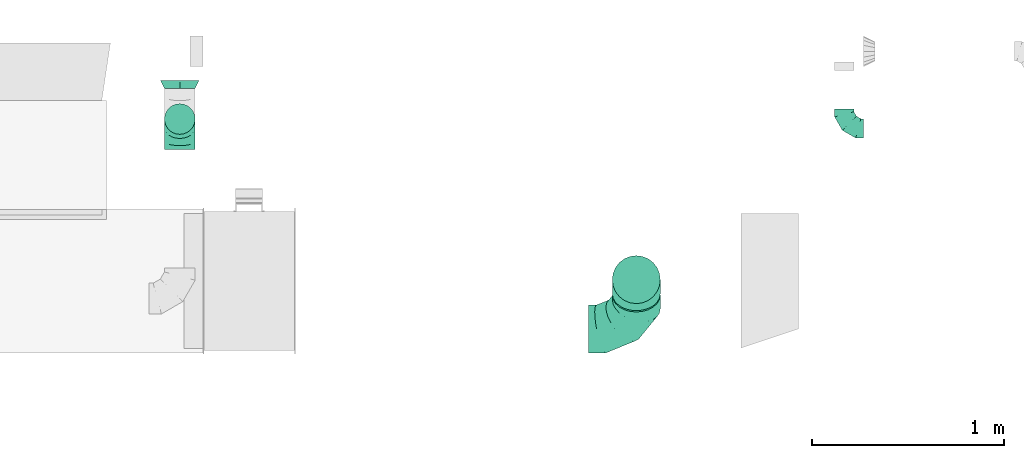
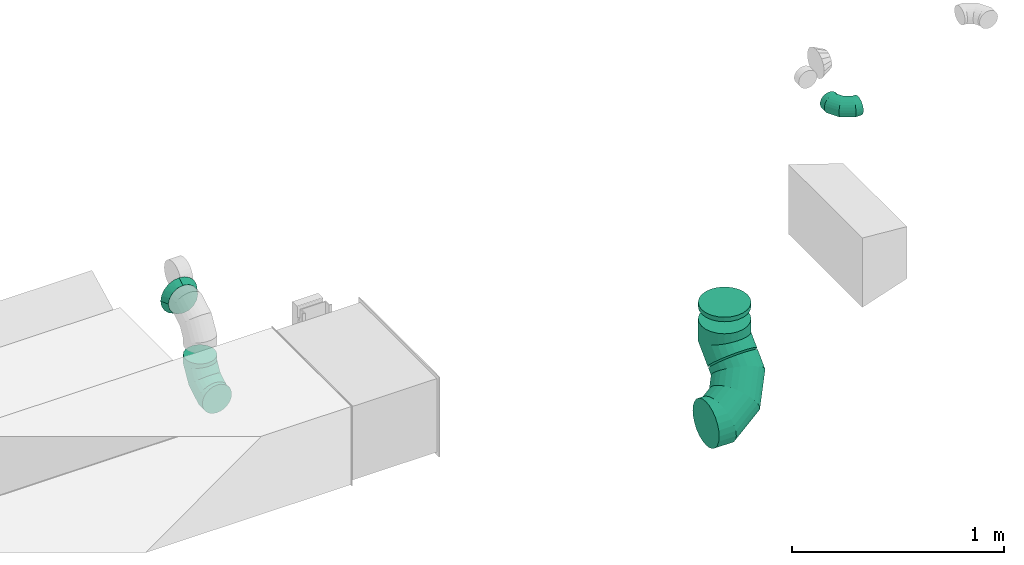
# One storey, part 17 of 62: 6 flow fittings.
"""IFC2X3 building model written with IfcOpenShell, lengths in millimetres."""

from ifc_helpers import new_model, entity, si_unit, converted_unit, derived_unit, direction, frame, origin, place, context, subcontext, project, spatial, faceted_brep, source, transform, mapped, material, type_object, type_shapes, element, save


model = new_model("IFC2X3")

# Units and contexts
model_context = context("Model", 3, precision=0.01, world=origin(), true_north=direction((6.12303176911189e-17, 1.0)))
body_context = subcontext(model_context, "Body", "Model", "MODEL_VIEW")
ifc_project = project(units=[si_unit("LENGTHUNIT", "METRE", prefix="MILLI"), si_unit("AREAUNIT", "SQUARE_METRE"), si_unit("VOLUMEUNIT", "CUBIC_METRE"), converted_unit("PLANEANGLEUNIT", "DEGREE", entity("IfcRatioMeasure", 0.0174532925199433), si_unit("PLANEANGLEUNIT", "RADIAN"), dimensions=[0, 0, 0, 0, 0, 0, 0]), si_unit("MASSUNIT", "GRAM", prefix="KILO"), derived_unit("MASSDENSITYUNIT", [(si_unit("MASSUNIT", "GRAM", prefix="KILO"), 1), (si_unit("LENGTHUNIT", "METRE"), -3)]), derived_unit("MOMENTOFINERTIAUNIT", [(si_unit("LENGTHUNIT", "METRE"), 4)]), si_unit("TIMEUNIT", "SECOND"), si_unit("FREQUENCYUNIT", "HERTZ"), si_unit("THERMODYNAMICTEMPERATUREUNIT", "DEGREE_CELSIUS"), derived_unit("THERMALTRANSMITTANCEUNIT", [(si_unit("MASSUNIT", "GRAM", prefix="KILO"), 1), (si_unit("THERMODYNAMICTEMPERATUREUNIT", "KELVIN"), -1), (si_unit("TIMEUNIT", "SECOND"), -3)]), derived_unit("VOLUMETRICFLOWRATEUNIT", [(si_unit("LENGTHUNIT", "METRE"), 3), (si_unit("TIMEUNIT", "SECOND"), -1)]), derived_unit("MASSFLOWRATEUNIT", [(si_unit("MASSUNIT", "GRAM", prefix="KILO"), 1), (si_unit("TIMEUNIT", "SECOND"), -1)]), derived_unit("ROTATIONALFREQUENCYUNIT", [(si_unit("TIMEUNIT", "SECOND"), -1)]), si_unit("ELECTRICCURRENTUNIT", "AMPERE"), si_unit("ELECTRICVOLTAGEUNIT", "VOLT"), si_unit("POWERUNIT", "WATT"), si_unit("FORCEUNIT", "NEWTON", prefix="KILO"), si_unit("ILLUMINANCEUNIT", "LUX"), si_unit("LUMINOUSFLUXUNIT", "LUMEN"), si_unit("LUMINOUSINTENSITYUNIT", "CANDELA"), derived_unit("USERDEFINED", [(si_unit("MASSUNIT", "GRAM", prefix="KILO"), -1), (si_unit("LENGTHUNIT", "METRE"), -2), (si_unit("TIMEUNIT", "SECOND"), 3), (si_unit("LUMINOUSFLUXUNIT", "LUMEN"), 1)]), derived_unit("LINEARVELOCITYUNIT", [(si_unit("LENGTHUNIT", "METRE"), 1), (si_unit("TIMEUNIT", "SECOND"), -1)]), si_unit("PRESSUREUNIT", "PASCAL"), derived_unit("USERDEFINED", [(si_unit("LENGTHUNIT", "METRE"), -2), (si_unit("MASSUNIT", "GRAM", prefix="KILO"), 1), (si_unit("TIMEUNIT", "SECOND"), -2)]), derived_unit("LINEARFORCEUNIT", [(si_unit("MASSUNIT", "GRAM", prefix="KILO"), 1), (si_unit("LENGTHUNIT", "METRE"), 1), (si_unit("TIMEUNIT", "SECOND"), -2), (si_unit("LENGTHUNIT", "METRE"), -1)]), derived_unit("PLANARFORCEUNIT", [(si_unit("MASSUNIT", "GRAM", prefix="KILO"), 1), (si_unit("LENGTHUNIT", "METRE"), 1), (si_unit("TIMEUNIT", "SECOND"), -2), (si_unit("LENGTHUNIT", "METRE"), -2)])], contexts=[model_context])

# Site, building, storey
site_placement = place(None, origin())
site = spatial("IfcSite", under=ifc_project, at=site_placement, CompositionType="ELEMENT")
building_placement = place(site_placement, origin())
building = spatial("IfcBuilding", under=site, at=building_placement, CompositionType="ELEMENT")
storey_placement = place(building_placement, frame((0.0, 0.0, 24000.0)))
storey = spatial("IfcBuildingStorey", under=building, at=storey_placement, CompositionType="ELEMENT", Elevation=24000.0)

# Flow fittings
ifc_material = material()
duct_fitting_type_1 = type_object("IfcDuctFittingType", PredefinedType="NOTDEFINED", material=ifc_material)
shared_shape_1 = source(origin(), body_context, "Body", "Brep", [
    faceted_brep([(-160.0, 0.0, -80.0), (-160.0, -20.71, -77.27), (-160.0, -40.0, -69.28), (-160.0, -56.57, -56.57), (-160.0, -69.28, -40.0), (-160.0, -77.27, -20.71), (-160.0, -80.0, 0.0), (-160.0, -77.27, 20.71), (-160.0, -69.28, 40.0), (-160.0, -56.57, 56.57), (-160.0, -40.0, 69.28), (-160.0, -20.71, 77.27), (-160.0, 0.0, 80.0), (-160.0, 20.71, 77.27), (-160.0, 40.0, 69.28), (-160.0, 56.57, 56.57), (-160.0, 69.28, 40.0), (-160.0, 77.27, 20.71), (-160.0, 80.0, 0.0), (-160.0, 77.27, -20.71), (-160.0, 69.28, -40.0), (-160.0, 56.57, -56.57), (-160.0, 40.0, -69.28), (-160.0, 20.71, -77.27), (-122.68, 20.71, 77.27), (-127.85, 40.0, 69.28), (-117.13, 0.0, 80.0), (-132.29, 56.57, 56.57), (-137.83, 77.27, 20.71), (-138.56, 80.0, 0.0), (-135.69, 69.28, 40.0), (-135.69, 69.28, -40.0), (-132.29, 56.57, -56.57), (-137.83, 77.27, -20.71), (-122.68, 20.71, -77.27), (-117.13, 0.0, -80.0), (-127.85, 40.0, -69.28), (-111.58, -20.71, -77.27), (-106.41, -40.0, -69.28), (-101.97, -56.57, -56.57), (-98.56, -69.28, -40.0), (-96.42, -77.27, -20.71), (-95.69, -80.0, 0.0), (-96.42, -77.27, 20.71), (-98.56, -69.28, 40.0), (-101.97, -56.57, 56.57), (-106.41, -40.0, 69.28), (-111.58, -20.71, 77.27), (-58.03, 58.03, 77.27), (-72.15, 72.15, 69.28), (-42.87, 42.87, 80.0), (-84.28, 84.28, 56.57), (-93.59, 93.59, 40.0), (-99.44, 99.44, 20.71), (-101.44, 101.44, 0.0), (-99.44, 99.44, -20.71), (-93.59, 93.59, -40.0), (-84.28, 84.28, -56.57), (-58.03, 58.03, -77.27), (-42.87, 42.87, -80.0), (-72.15, 72.15, -69.28), (-27.71, 27.71, -77.27), (-13.59, 13.59, -69.28), (-1.46, 1.46, -56.57), (7.85, -7.85, -40.0), (13.7, -13.7, -20.71), (15.69, -15.69, 0.0), (13.7, -13.7, 20.71), (7.85, -7.85, 40.0), (-1.46, 1.46, 56.57), (-13.59, 13.59, 69.28), (-27.71, 27.71, 77.27), (-20.71, 122.68, 77.27), (-40.0, 127.85, 69.28), (0.0, 117.13, 80.0), (-56.57, 132.29, 56.57), (-69.28, 135.69, 40.0), (-77.27, 137.83, 20.71), (-80.0, 138.56, 0.0), (-77.27, 137.83, -20.71), (-69.28, 135.69, -40.0), (-56.57, 132.29, -56.57), (-20.71, 122.68, -77.27), (0.0, 117.13, -80.0), (-40.0, 127.85, -69.28), (20.71, 111.58, -77.27), (40.0, 106.41, -69.28), (56.57, 101.97, -56.57), (69.28, 98.56, -40.0), (77.27, 96.42, -20.71), (80.0, 95.69, 0.0), (77.27, 96.42, 20.71), (69.28, 98.56, 40.0), (56.57, 101.97, 56.57), (40.0, 106.41, 69.28), (20.71, 111.58, 77.27), (-20.71, 160.0, -77.27), (-40.0, 160.0, -69.28), (-56.57, 160.0, -56.57), (-69.28, 160.0, -40.0), (-77.27, 160.0, -20.71), (-80.0, 160.0, 0.0), (-77.27, 160.0, 20.71), (-69.28, 160.0, 40.0), (-56.57, 160.0, 56.57), (-40.0, 160.0, 69.28), (-20.71, 160.0, 77.27), (0.0, 160.0, 80.0), (20.71, 160.0, 77.27), (40.0, 160.0, 69.28), (56.57, 160.0, 56.57), (69.28, 160.0, 40.0), (77.27, 160.0, 20.71), (80.0, 160.0, 0.0), (77.27, 160.0, -20.71), (69.28, 160.0, -40.0), (56.57, 160.0, -56.57), (40.0, 160.0, -69.28), (20.71, 160.0, -77.27), (0.0, 160.0, -80.0)], [[[0, 1, 2, 3, 4, 5, 6, 7, 8, 9, 10, 11, 12, 13, 14, 15, 16, 17, 18, 19, 20, 21, 22, 23]], [[24, 25, 14, 13]], [[26, 24, 13, 12]], [[14, 25, 27, 15]], [[28, 29, 18, 17]], [[30, 28, 17, 16]], [[15, 27, 30, 16]], [[20, 31, 32, 21]], [[33, 31, 20, 19]], [[18, 29, 33, 19]], [[34, 35, 0, 23]], [[36, 34, 23, 22]], [[32, 36, 22, 21]], [[1, 0, 35, 37]], [[2, 1, 37, 38]], [[3, 2, 38, 39]], [[5, 4, 40, 41]], [[6, 5, 41, 42]], [[39, 40, 4, 3]], [[6, 42, 43, 7]], [[7, 43, 44, 8]], [[8, 44, 45, 9]], [[9, 45, 46, 10]], [[10, 46, 47, 11]], [[26, 12, 11, 47]], [[48, 49, 25, 24]], [[50, 48, 24, 26]], [[27, 25, 49, 51]], [[52, 53, 28, 30]], [[51, 52, 30, 27]], [[29, 28, 53, 54]], [[55, 56, 31, 33]], [[54, 55, 33, 29]], [[32, 31, 56, 57]], [[58, 59, 35, 34]], [[60, 58, 34, 36]], [[57, 60, 36, 32]], [[37, 35, 59, 61]], [[38, 37, 61, 62]], [[39, 38, 62, 63]], [[41, 40, 64, 65]], [[42, 41, 65, 66]], [[63, 64, 40, 39]], [[43, 42, 66, 67]], [[44, 43, 67, 68]], [[68, 69, 45, 44]], [[46, 45, 69, 70]], [[47, 46, 70, 71]], [[26, 47, 71, 50]], [[72, 73, 49, 48]], [[74, 72, 48, 50]], [[51, 49, 73, 75]], [[76, 77, 53, 52]], [[75, 76, 52, 51]], [[54, 53, 77, 78]], [[79, 80, 56, 55]], [[78, 79, 55, 54]], [[57, 56, 80, 81]], [[82, 83, 59, 58]], [[84, 82, 58, 60]], [[81, 84, 60, 57]], [[61, 59, 83, 85]], [[62, 61, 85, 86]], [[63, 62, 86, 87]], [[65, 64, 88, 89]], [[66, 65, 89, 90]], [[87, 88, 64, 63]], [[67, 66, 90, 91]], [[68, 67, 91, 92]], [[92, 93, 69, 68]], [[70, 69, 93, 94]], [[71, 70, 94, 95]], [[50, 71, 95, 74]], [[96, 97, 98, 99, 100, 101, 102, 103, 104, 105, 106, 107, 108, 109, 110, 111, 112, 113, 114, 115, 116, 117, 118, 119]], [[72, 74, 107, 106]], [[73, 72, 106, 105]], [[75, 73, 105, 104]], [[77, 76, 103, 102]], [[78, 77, 102, 101]], [[75, 104, 103, 76]], [[78, 101, 100, 79]], [[79, 100, 99, 80]], [[80, 99, 98, 81]], [[84, 97, 96, 82]], [[82, 96, 119, 83]], [[84, 81, 98, 97]], [[118, 117, 86, 85]], [[119, 118, 85, 83]], [[116, 87, 86, 117]], [[88, 115, 114, 89]], [[89, 114, 113, 90]], [[115, 88, 87, 116]], [[112, 111, 92, 91]], [[113, 112, 91, 90]], [[111, 110, 93, 92]], [[95, 94, 109, 108]], [[74, 95, 108, 107]], [[110, 109, 94, 93]]]),
])
type_shapes(duct_fitting_type_1, [shared_shape_1])
flow_fitting_1_placement = place(storey_placement, frame((31130.5, 2136.51, 3220.0), z_axis=(-1.0, 0.0, 0.0), x_axis=(0.0, 0.0, -1.0)))
element("IfcFlowFitting", 1, at=flow_fitting_1_placement, inside=storey, type_object=duct_fitting_type_1, material=ifc_material, context=body_context, shape_type="MappedRepresentation", body=[
    mapped(shared_shape_1, transform((0.0, 0.0, 0.0), scale=1.0)),
])
duct_fitting_type_2 = type_object("IfcDuctFittingType", PredefinedType="NOTDEFINED", material=ifc_material)
shared_shape_2 = source(origin(), body_context, "Body", "Brep", [
    faceted_brep([(-100.0, 0.0, -50.0), (-100.0, -12.94, -48.3), (-100.0, -25.0, -43.3), (-100.0, -35.36, -35.36), (-100.0, -43.3, -25.0), (-100.0, -48.3, -12.94), (-100.0, -50.0, 0.0), (-100.0, -48.3, 12.94), (-100.0, -43.3, 25.0), (-100.0, -35.36, 35.36), (-100.0, -25.0, 43.3), (-100.0, -12.94, 48.3), (-100.0, 0.0, 50.0), (-100.0, 12.94, 48.3), (-100.0, 25.0, 43.3), (-100.0, 35.36, 35.36), (-100.0, 43.3, 25.0), (-100.0, 48.3, 12.94), (-100.0, 50.0, 0.0), (-100.0, 48.3, -12.94), (-100.0, 43.3, -25.0), (-100.0, 35.36, -35.36), (-100.0, 25.0, -43.3), (-100.0, 12.94, -48.3), (-76.67, 12.94, 48.3), (-79.9, 25.0, 43.3), (-73.21, 0.0, 50.0), (-82.68, 35.36, 35.36), (-86.15, 48.3, 12.94), (-86.6, 50.0, 0.0), (-84.81, 43.3, 25.0), (-84.81, 43.3, -25.0), (-82.68, 35.36, -35.36), (-86.15, 48.3, -12.94), (-76.67, 12.94, -48.3), (-73.21, 0.0, -50.0), (-79.9, 25.0, -43.3), (-69.74, -12.94, -48.3), (-66.51, -25.0, -43.3), (-63.73, -35.36, -35.36), (-61.6, -43.3, -25.0), (-60.26, -48.3, -12.94), (-59.81, -50.0, 0.0), (-60.26, -48.3, 12.94), (-61.6, -43.3, 25.0), (-63.73, -35.36, 35.36), (-66.51, -25.0, 43.3), (-69.74, -12.94, 48.3), (-36.27, 36.27, 48.3), (-45.1, 45.1, 43.3), (-26.79, 26.79, 50.0), (-52.68, 52.68, 35.36), (-58.49, 58.49, 25.0), (-62.15, 62.15, 12.94), (-63.4, 63.4, 0.0), (-62.15, 62.15, -12.94), (-58.49, 58.49, -25.0), (-52.68, 52.68, -35.36), (-36.27, 36.27, -48.3), (-26.79, 26.79, -50.0), (-45.1, 45.1, -43.3), (-17.32, 17.32, -48.3), (-8.49, 8.49, -43.3), (-0.91, 0.91, -35.36), (4.9, -4.9, -25.0), (8.56, -8.56, -12.94), (9.81, -9.81, 0.0), (8.56, -8.56, 12.94), (4.9, -4.9, 25.0), (-0.91, 0.91, 35.36), (-8.49, 8.49, 43.3), (-17.32, 17.32, 48.3), (-12.94, 76.67, 48.3), (-25.0, 79.9, 43.3), (0.0, 73.21, 50.0), (-35.36, 82.68, 35.36), (-43.3, 84.81, 25.0), (-48.3, 86.15, 12.94), (-50.0, 86.6, 0.0), (-48.3, 86.15, -12.94), (-43.3, 84.81, -25.0), (-35.36, 82.68, -35.36), (-12.94, 76.67, -48.3), (0.0, 73.21, -50.0), (-25.0, 79.9, -43.3), (12.94, 69.74, -48.3), (25.0, 66.51, -43.3), (35.36, 63.73, -35.36), (43.3, 61.6, -25.0), (48.3, 60.26, -12.94), (50.0, 59.81, 0.0), (48.3, 60.26, 12.94), (43.3, 61.6, 25.0), (35.36, 63.73, 35.36), (25.0, 66.51, 43.3), (12.94, 69.74, 48.3), (-12.94, 100.0, -48.3), (-25.0, 100.0, -43.3), (-35.36, 100.0, -35.36), (-43.3, 100.0, -25.0), (-48.3, 100.0, -12.94), (-50.0, 100.0, 0.0), (-48.3, 100.0, 12.94), (-43.3, 100.0, 25.0), (-35.36, 100.0, 35.36), (-25.0, 100.0, 43.3), (-12.94, 100.0, 48.3), (0.0, 100.0, 50.0), (12.94, 100.0, 48.3), (25.0, 100.0, 43.3), (35.36, 100.0, 35.36), (43.3, 100.0, 25.0), (48.3, 100.0, 12.94), (50.0, 100.0, 0.0), (48.3, 100.0, -12.94), (43.3, 100.0, -25.0), (35.36, 100.0, -35.36), (25.0, 100.0, -43.3), (12.94, 100.0, -48.3), (0.0, 100.0, -50.0)], [[[0, 1, 2, 3, 4, 5, 6, 7, 8, 9, 10, 11, 12, 13, 14, 15, 16, 17, 18, 19, 20, 21, 22, 23]], [[24, 25, 14, 13]], [[26, 24, 13, 12]], [[14, 25, 27, 15]], [[28, 29, 18, 17]], [[30, 28, 17, 16]], [[15, 27, 30, 16]], [[20, 31, 32, 21]], [[33, 31, 20, 19]], [[18, 29, 33, 19]], [[34, 35, 0, 23]], [[36, 34, 23, 22]], [[32, 36, 22, 21]], [[2, 1, 37, 38]], [[3, 2, 38, 39]], [[0, 35, 37, 1]], [[5, 4, 40, 41]], [[6, 5, 41, 42]], [[3, 39, 40, 4]], [[6, 42, 43, 7]], [[7, 43, 44, 8]], [[8, 44, 45, 9]], [[10, 46, 47, 11]], [[11, 47, 26, 12]], [[10, 9, 45, 46]], [[48, 49, 25, 24]], [[50, 48, 24, 26]], [[27, 25, 49, 51]], [[52, 53, 28, 30]], [[51, 52, 30, 27]], [[29, 28, 53, 54]], [[55, 56, 31, 33]], [[54, 55, 33, 29]], [[57, 32, 31, 56]], [[58, 59, 35, 34]], [[60, 58, 34, 36]], [[57, 60, 36, 32]], [[37, 35, 59, 61]], [[38, 37, 61, 62]], [[39, 38, 62, 63]], [[41, 40, 64, 65]], [[42, 41, 65, 66]], [[63, 64, 40, 39]], [[43, 42, 66, 67]], [[44, 43, 67, 68]], [[68, 69, 45, 44]], [[46, 45, 69, 70]], [[47, 46, 70, 71]], [[26, 47, 71, 50]], [[72, 73, 49, 48]], [[74, 72, 48, 50]], [[51, 49, 73, 75]], [[76, 77, 53, 52]], [[75, 76, 52, 51]], [[54, 53, 77, 78]], [[79, 80, 56, 55]], [[78, 79, 55, 54]], [[81, 57, 56, 80]], [[82, 83, 59, 58]], [[84, 82, 58, 60]], [[81, 84, 60, 57]], [[61, 59, 83, 85]], [[62, 61, 85, 86]], [[63, 62, 86, 87]], [[65, 64, 88, 89]], [[66, 65, 89, 90]], [[87, 88, 64, 63]], [[67, 66, 90, 91]], [[68, 67, 91, 92]], [[92, 93, 69, 68]], [[70, 69, 93, 94]], [[71, 70, 94, 95]], [[50, 71, 95, 74]], [[96, 97, 98, 99, 100, 101, 102, 103, 104, 105, 106, 107, 108, 109, 110, 111, 112, 113, 114, 115, 116, 117, 118, 119]], [[72, 74, 107, 106]], [[73, 72, 106, 105]], [[75, 73, 105, 104]], [[77, 76, 103, 102]], [[78, 77, 102, 101]], [[75, 104, 103, 76]], [[78, 101, 100, 79]], [[79, 100, 99, 80]], [[80, 99, 98, 81]], [[96, 119, 83, 82]], [[97, 96, 82, 84]], [[84, 81, 98, 97]], [[83, 119, 118, 85]], [[85, 118, 117, 86]], [[86, 117, 116, 87]], [[88, 115, 114, 89]], [[89, 114, 113, 90]], [[87, 116, 115, 88]], [[91, 90, 113, 112]], [[92, 91, 112, 111]], [[93, 92, 111, 110]], [[95, 94, 109, 108]], [[74, 95, 108, 107]], [[110, 109, 94, 93]]]),
])
type_shapes(duct_fitting_type_2, [shared_shape_2])
flow_fitting_2_placement = place(storey_placement, frame((34589.9, 2087.55, 3600.0), z_axis=(0.0, 0.0, 1.0), x_axis=(0.0, -1.0, 0.0)))
element("IfcFlowFitting", 2, at=flow_fitting_2_placement, inside=storey, type_object=duct_fitting_type_2, material=ifc_material, context=body_context, shape_type="MappedRepresentation", body=[
    mapped(shared_shape_2, transform((0.0, 0.0, 0.0), scale=1.0)),
])
duct_fitting_type_3 = type_object("IfcDuctFittingType", PredefinedType="NOTDEFINED", material=ifc_material)
shared_shape_3 = source(origin(), body_context, "Body", "Brep", [
    faceted_brep([(-250.0, 0.0, -125.0), (-250.0, -32.35, -120.74), (-250.0, -62.5, -108.25), (-250.0, -88.39, -88.39), (-250.0, -108.25, -62.5), (-250.0, -120.74, -32.35), (-250.0, -125.0, 0.0), (-250.0, -120.74, 32.35), (-250.0, -108.25, 62.5), (-250.0, -88.39, 88.39), (-250.0, -62.5, 108.25), (-250.0, -32.35, 120.74), (-250.0, 0.0, 125.0), (-250.0, 32.35, 120.74), (-250.0, 62.5, 108.25), (-250.0, 88.39, 88.39), (-250.0, 108.25, 62.5), (-250.0, 120.74, 32.35), (-250.0, 125.0, 0.0), (-250.0, 120.74, -32.35), (-250.0, 108.25, -62.5), (-250.0, 88.39, -88.39), (-250.0, 62.5, -108.25), (-250.0, 32.35, -120.74), (-191.68, 32.35, 120.74), (-199.76, 62.5, 108.25), (-183.01, 0.0, 125.0), (-206.7, 88.39, 88.39), (-215.37, 120.74, 32.35), (-216.51, 125.0, 0.0), (-212.02, 108.25, 62.5), (-212.02, 108.25, -62.5), (-206.7, 88.39, -88.39), (-215.37, 120.74, -32.35), (-191.68, 32.35, -120.74), (-183.01, 0.0, -125.0), (-199.76, 62.5, -108.25), (-174.34, -32.35, -120.74), (-166.27, -62.5, -108.25), (-159.33, -88.39, -88.39), (-154.01, -108.25, -62.5), (-150.66, -120.74, -32.35), (-149.52, -125.0, 0.0), (-150.66, -120.74, 32.35), (-154.01, -108.25, 62.5), (-159.33, -88.39, 88.39), (-166.27, -62.5, 108.25), (-174.34, -32.35, 120.74), (-90.67, 90.67, 120.74), (-112.74, 112.74, 108.25), (-66.99, 66.99, 125.0), (-131.69, 131.69, 88.39), (-146.23, 146.23, 62.5), (-155.38, 155.38, 32.35), (-158.49, 158.49, 0.0), (-155.38, 155.38, -32.35), (-146.23, 146.23, -62.5), (-131.69, 131.69, -88.39), (-90.67, 90.67, -120.74), (-66.99, 66.99, -125.0), (-112.74, 112.74, -108.25), (-43.3, 43.3, -120.74), (-21.23, 21.23, -108.25), (-2.28, 2.28, -88.39), (12.26, -12.26, -62.5), (21.4, -21.4, -32.35), (24.52, -24.52, 0.0), (21.4, -21.4, 32.35), (12.26, -12.26, 62.5), (-2.28, 2.28, 88.39), (-21.23, 21.23, 108.25), (-43.3, 43.3, 120.74), (-32.35, 191.68, 120.74), (-62.5, 199.76, 108.25), (0.0, 183.01, 125.0), (-88.39, 206.7, 88.39), (-108.25, 212.02, 62.5), (-120.74, 215.37, 32.35), (-125.0, 216.51, 0.0), (-120.74, 215.37, -32.35), (-108.25, 212.02, -62.5), (-88.39, 206.7, -88.39), (-32.35, 191.68, -120.74), (0.0, 183.01, -125.0), (-62.5, 199.76, -108.25), (32.35, 174.34, -120.74), (62.5, 166.27, -108.25), (88.39, 159.33, -88.39), (108.25, 154.01, -62.5), (120.74, 150.66, -32.35), (125.0, 149.52, 0.0), (120.74, 150.66, 32.35), (108.25, 154.01, 62.5), (88.39, 159.33, 88.39), (62.5, 166.27, 108.25), (32.35, 174.34, 120.74), (-32.35, 250.0, -120.74), (-62.5, 250.0, -108.25), (-88.39, 250.0, -88.39), (-108.25, 250.0, -62.5), (-120.74, 250.0, -32.35), (-125.0, 250.0, 0.0), (-120.74, 250.0, 32.35), (-108.25, 250.0, 62.5), (-88.39, 250.0, 88.39), (-62.5, 250.0, 108.25), (-32.35, 250.0, 120.74), (0.0, 250.0, 125.0), (32.35, 250.0, 120.74), (62.5, 250.0, 108.25), (88.39, 250.0, 88.39), (108.25, 250.0, 62.5), (120.74, 250.0, 32.35), (125.0, 250.0, 0.0), (120.74, 250.0, -32.35), (108.25, 250.0, -62.5), (88.39, 250.0, -88.39), (62.5, 250.0, -108.25), (32.35, 250.0, -120.74), (0.0, 250.0, -125.0)], [[[0, 1, 2, 3, 4, 5, 6, 7, 8, 9, 10, 11, 12, 13, 14, 15, 16, 17, 18, 19, 20, 21, 22, 23]], [[24, 25, 14, 13]], [[26, 24, 13, 12]], [[14, 25, 27, 15]], [[28, 29, 18, 17]], [[30, 28, 17, 16]], [[15, 27, 30, 16]], [[20, 31, 32, 21]], [[33, 31, 20, 19]], [[18, 29, 33, 19]], [[34, 35, 0, 23]], [[36, 34, 23, 22]], [[21, 32, 36, 22]], [[1, 0, 35, 37]], [[2, 1, 37, 38]], [[38, 39, 3, 2]], [[5, 4, 40, 41]], [[6, 5, 41, 42]], [[39, 40, 4, 3]], [[6, 42, 43, 7]], [[7, 43, 44, 8]], [[8, 44, 45, 9]], [[9, 45, 46, 10]], [[10, 46, 47, 11]], [[26, 12, 11, 47]], [[48, 49, 25, 24]], [[50, 48, 24, 26]], [[27, 25, 49, 51]], [[52, 53, 28, 30]], [[51, 52, 30, 27]], [[29, 28, 53, 54]], [[55, 56, 31, 33]], [[54, 55, 33, 29]], [[32, 31, 56, 57]], [[58, 59, 35, 34]], [[60, 58, 34, 36]], [[57, 60, 36, 32]], [[37, 35, 59, 61]], [[38, 37, 61, 62]], [[39, 38, 62, 63]], [[41, 40, 64, 65]], [[42, 41, 65, 66]], [[63, 64, 40, 39]], [[43, 42, 66, 67]], [[44, 43, 67, 68]], [[68, 69, 45, 44]], [[46, 45, 69, 70]], [[47, 46, 70, 71]], [[26, 47, 71, 50]], [[72, 73, 49, 48]], [[74, 72, 48, 50]], [[51, 49, 73, 75]], [[76, 77, 53, 52]], [[75, 76, 52, 51]], [[54, 53, 77, 78]], [[79, 80, 56, 55]], [[78, 79, 55, 54]], [[57, 56, 80, 81]], [[82, 83, 59, 58]], [[84, 82, 58, 60]], [[81, 84, 60, 57]], [[61, 59, 83, 85]], [[62, 61, 85, 86]], [[63, 62, 86, 87]], [[65, 64, 88, 89]], [[66, 65, 89, 90]], [[87, 88, 64, 63]], [[67, 66, 90, 91]], [[68, 67, 91, 92]], [[92, 93, 69, 68]], [[70, 69, 93, 94]], [[71, 70, 94, 95]], [[50, 71, 95, 74]], [[96, 97, 98, 99, 100, 101, 102, 103, 104, 105, 106, 107, 108, 109, 110, 111, 112, 113, 114, 115, 116, 117, 118, 119]], [[72, 74, 107, 106]], [[73, 72, 106, 105]], [[75, 73, 105, 104]], [[77, 76, 103, 102]], [[78, 77, 102, 101]], [[75, 104, 103, 76]], [[78, 101, 100, 79]], [[79, 100, 99, 80]], [[80, 99, 98, 81]], [[84, 97, 96, 82]], [[82, 96, 119, 83]], [[84, 81, 98, 97]], [[83, 119, 118, 85]], [[85, 118, 117, 86]], [[116, 87, 86, 117]], [[88, 115, 114, 89]], [[89, 114, 113, 90]], [[115, 88, 87, 116]], [[91, 90, 113, 112]], [[92, 91, 112, 111]], [[111, 110, 93, 92]], [[95, 94, 109, 108]], [[74, 95, 108, 107]], [[110, 109, 94, 93]]]),
])
type_shapes(duct_fitting_type_3, [shared_shape_3])
flow_fitting_3_placement = place(storey_placement, frame((33507.3, 1043.17, 2900.0), z_axis=(0.0, 0.707106781185657, -0.707106781187438), x_axis=(0.0, -0.707106781187438, -0.707106781185657)))
element("IfcFlowFitting", 3, at=flow_fitting_3_placement, inside=storey, type_object=duct_fitting_type_3, material=ifc_material, context=body_context, shape_type="MappedRepresentation", body=[
    mapped(shared_shape_3, transform((0.0, 0.0, 0.0), scale=1.0)),
])
duct_fitting_type_4 = type_object("IfcDuctFittingType", PredefinedType="NOTDEFINED", material=ifc_material)
shared_shape_4 = source(origin(), body_context, "Body", "Brep", [
    faceted_brep([(20.0, 0.0, -125.0), (20.0, 32.35, -120.74), (20.0, 62.5, -108.25), (20.0, 88.39, -88.39), (20.0, 108.25, -62.5), (20.0, 120.74, -32.35), (20.0, 125.0, 0.0), (20.0, 120.74, 32.35), (20.0, 108.25, 62.5), (20.0, 88.39, 88.39), (20.0, 62.5, 108.25), (20.0, 32.35, 120.74), (20.0, 0.0, 125.0), (20.0, -32.35, 120.74), (20.0, -62.5, 108.25), (20.0, -88.39, 88.39), (20.0, -108.25, 62.5), (20.0, -120.74, 32.35), (20.0, -125.0, 0.0), (20.0, -120.74, -32.35), (20.0, -108.25, -62.5), (20.0, -88.39, -88.39), (20.0, -62.5, -108.25), (20.0, -32.35, -120.74), (0.0, 0.0, 125.0), (-6.1, 0.0, 125.0), (-6.1, -32.35, 120.74), (0.0, -32.35, 120.74), (-6.1, -62.5, 108.25), (0.0, -62.5, 108.25), (0.0, -88.39, 88.39), (-6.1, -88.39, 88.39), (0.0, -108.25, 62.5), (-6.1, -108.25, 62.5), (-6.1, -120.74, 32.35), (0.0, -120.74, 32.35), (-6.1, -125.0, 0.0), (0.0, -125.0, 0.0), (-6.1, -120.74, -32.35), (0.0, -120.74, -32.35), (-6.1, -108.25, -62.5), (0.0, -108.25, -62.5), (0.0, -88.39, -88.39), (-6.1, -88.39, -88.39), (0.0, -62.5, -108.25), (-6.1, -62.5, -108.25), (-6.1, -32.35, -120.74), (0.0, -32.35, -120.74), (-6.1, 0.0, -125.0), (0.0, 0.0, -125.0), (-6.1, 32.35, -120.74), (0.0, 32.35, -120.74), (-6.1, 62.5, -108.25), (0.0, 62.5, -108.25), (0.0, 88.39, -88.39), (-6.1, 88.39, -88.39), (0.0, 108.25, -62.5), (-6.1, 108.25, -62.5), (-6.1, 120.74, -32.35), (0.0, 120.74, -32.35), (-6.1, 125.0, 0.0), (0.0, 125.0, 0.0), (-6.1, 120.74, 32.35), (0.0, 120.74, 32.35), (-6.1, 108.25, 62.5), (0.0, 108.25, 62.5), (0.0, 88.39, 88.39), (-6.1, 88.39, 88.39), (0.0, 62.5, 108.25), (-6.1, 62.5, 108.25), (-6.1, 32.35, 120.74), (0.0, 32.35, 120.74)], [[[0, 1, 2, 3, 4, 5, 6, 7, 8, 9, 10, 11, 12, 13, 14, 15, 16, 17, 18, 19, 20, 21, 22, 23]], [[13, 12, 24, 25, 26, 27]], [[14, 13, 27, 26, 28, 29]], [[30, 15, 14, 29, 28, 31]], [[17, 16, 32, 33, 34, 35]], [[18, 17, 35, 34, 36, 37]], [[32, 16, 15, 30, 31, 33]], [[19, 18, 37, 36, 38, 39]], [[20, 19, 39, 38, 40, 41]], [[42, 21, 20, 41, 40, 43]], [[23, 22, 44, 45, 46, 47]], [[0, 23, 47, 46, 48, 49]], [[44, 22, 21, 42, 43, 45]], [[1, 0, 49, 48, 50, 51]], [[2, 1, 51, 50, 52, 53]], [[54, 3, 2, 53, 52, 55]], [[5, 4, 56, 57, 58, 59]], [[6, 5, 59, 58, 60, 61]], [[56, 4, 3, 54, 55, 57]], [[7, 6, 61, 60, 62, 63]], [[8, 7, 63, 62, 64, 65]], [[66, 9, 8, 65, 64, 67]], [[11, 10, 68, 69, 70, 71]], [[12, 11, 71, 70, 25, 24]], [[68, 10, 9, 66, 67, 69]], [[46, 45, 43, 40, 38, 36, 34, 33, 31, 28, 26, 25, 70, 69, 67, 64, 62, 60, 58, 57, 55, 52, 50, 48]]]),
])
type_shapes(duct_fitting_type_4, [shared_shape_4])
flow_fitting_4_placement = place(storey_placement, frame((33507.3, 1300.16, 3350.0), z_axis=(1.0, 0.0, 0.0), x_axis=(0.0, 0.0, -1.0)))
element("IfcFlowFitting", 4, at=flow_fitting_4_placement, inside=storey, type_object=duct_fitting_type_4, material=ifc_material, context=body_context, shape_type="MappedRepresentation", body=[
    mapped(shared_shape_4, transform((0.0, 0.0, 0.0), scale=1.0)),
])
duct_fitting_type_5 = type_object("IfcDuctFittingType", PredefinedType="NOTDEFINED", material=ifc_material)
shared_shape_5 = source(origin(), body_context, "Body", "Brep", [
    faceted_brep([(40.0, -73.91, 30.61), (40.0, -76.96, 15.31), (40.0, -80.0, 0.0), (40.0, -76.96, -15.31), (40.0, -73.91, -30.61), (40.0, -65.24, -43.59), (40.0, -56.57, -56.57), (40.0, -43.59, -65.24), (40.0, -30.61, -73.91), (40.0, -15.31, -76.96), (40.0, 0.0, -80.0), (40.0, 15.31, -76.96), (40.0, 30.61, -73.91), (40.0, 43.59, -65.24), (40.0, 56.57, -56.57), (40.0, 65.24, -43.59), (40.0, 73.91, -30.61), (40.0, 76.96, -15.31), (40.0, 80.0, 0.0), (40.0, 76.96, 15.31), (40.0, 73.91, 30.61), (40.0, 65.24, 43.59), (40.0, 56.57, 56.57), (40.0, 43.59, 65.24), (40.0, 30.61, 73.91), (40.0, 15.31, 76.96), (40.0, 0.0, 80.0), (40.0, -15.31, 76.96), (40.0, -30.61, 73.91), (40.0, -43.59, 65.24), (40.0, -56.57, 56.57), (40.0, -65.24, 43.59), (0.0, -100.0, 0.0), (0.0, -95.11, 30.9), (0.0, -80.9, 58.78), (0.0, -58.78, 80.9), (0.0, -30.9, 95.11), (0.0, 0.0, 100.0), (0.0, 30.9, 95.11), (0.0, 58.78, 80.9), (0.0, 80.9, 58.78), (0.0, 95.11, 30.9), (0.0, 100.0, 0.0), (0.0, 95.11, -30.9), (0.0, 80.9, -58.78), (0.0, 58.78, -80.9), (0.0, 30.9, -95.11), (0.0, 0.0, -100.0), (0.0, -30.9, -95.11), (0.0, -58.78, -80.9), (0.0, -80.9, -58.78), (0.0, -95.11, -30.9)], [[[0, 1, 2, 3, 4, 5, 6, 7, 8, 9, 10, 11, 12, 13, 14, 15, 16, 17, 18, 19, 20, 21, 22, 23, 24, 25, 26, 27, 28, 29, 30, 31]], [[32, 33, 34, 35, 36, 37, 38, 39, 40, 41, 42, 43, 44, 45, 46, 47, 48, 49, 50, 51]], [[37, 25, 38]], [[25, 24, 38]], [[24, 39, 38]], [[41, 20, 19]], [[25, 37, 26]], [[39, 24, 23, 22]], [[42, 19, 18]], [[20, 40, 22, 21]], [[41, 40, 20]], [[42, 41, 19]], [[22, 40, 39]], [[32, 1, 33]], [[1, 0, 33]], [[0, 34, 33]], [[36, 28, 27]], [[1, 32, 2]], [[34, 0, 31, 30]], [[37, 27, 26]], [[28, 35, 30, 29]], [[36, 35, 28]], [[37, 36, 27]], [[30, 35, 34]], [[47, 9, 48]], [[9, 8, 48]], [[8, 49, 48]], [[51, 4, 3]], [[9, 47, 10]], [[49, 8, 7, 6]], [[32, 3, 2]], [[4, 50, 6, 5]], [[51, 50, 4]], [[32, 51, 3]], [[6, 50, 49]], [[42, 17, 43]], [[17, 16, 43]], [[16, 44, 43]], [[46, 12, 11]], [[17, 42, 18]], [[44, 16, 15, 14]], [[47, 11, 10]], [[12, 45, 14, 13]], [[46, 45, 12]], [[47, 46, 11]], [[14, 45, 44]]]),
])
type_shapes(duct_fitting_type_5, [shared_shape_5])
flow_fitting_5_placement = place(storey_placement, frame((31130.5, 2336.51, 3600.0), z_axis=(0.0, 0.0, 1.0), x_axis=(0.0, -1.0, 0.0)))
element("IfcFlowFitting", 5, at=flow_fitting_5_placement, inside=storey, type_object=duct_fitting_type_5, material=ifc_material, context=body_context, shape_type="MappedRepresentation", body=[
    mapped(shared_shape_5, transform((0.0, 0.0, 0.0), scale=1.0)),
])
duct_fitting_type_6 = type_object("IfcDuctFittingType", PredefinedType="NOTDEFINED", material=ifc_material)
shared_shape_6 = source(origin(), body_context, "Body", "Brep", [
    faceted_brep([(-103.55, 0.0, -125.0), (-103.55, -32.35, -120.74), (-103.55, -62.5, -108.25), (-103.55, -88.39, -88.39), (-103.55, -108.25, -62.5), (-103.55, -120.74, -32.35), (-103.55, -125.0, 0.0), (-103.55, -120.74, 32.35), (-103.55, -108.25, 62.5), (-103.55, -88.39, 88.39), (-103.55, -62.5, 108.25), (-103.55, -32.35, 120.74), (-103.55, 0.0, 125.0), (-103.55, 32.35, 120.74), (-103.55, 62.5, 108.25), (-103.55, 88.39, 88.39), (-103.55, 108.25, 62.5), (-103.55, 120.74, 32.35), (-103.55, 125.0, 0.0), (-103.55, 120.74, -32.35), (-103.55, 108.25, -62.5), (-103.55, 88.39, -88.39), (-103.55, 62.5, -108.25), (-103.55, 32.35, -120.74), (-13.4, 32.35, 120.74), (-25.89, 62.5, 108.25), (0.0, 0.0, 125.0), (-36.61, 88.39, 88.39), (-44.84, 108.25, 62.5), (-50.01, 120.74, 32.35), (-51.78, 125.0, 0.0), (-50.01, 120.74, -32.35), (-44.84, 108.25, -62.5), (-36.61, 88.39, -88.39), (-13.4, 32.35, -120.74), (0.0, 0.0, -125.0), (-25.89, 62.5, -108.25), (13.4, -32.35, -120.74), (25.89, -62.5, -108.25), (36.61, -88.39, -88.39), (44.84, -108.25, -62.5), (50.01, -120.74, -32.35), (51.78, -125.0, 0.0), (50.01, -120.74, 32.35), (44.84, -108.25, 62.5), (36.61, -88.39, 88.39), (25.89, -62.5, 108.25), (13.4, -32.35, 120.74), (73.22, 73.22, 125.0), (50.35, 96.1, 120.74), (29.03, 117.42, 108.25), (10.72, 135.72, 88.39), (-3.32, 149.77, 62.5), (-12.15, 158.6, 32.35), (-15.17, 161.61, 0.0), (-12.15, 158.6, -32.35), (-3.32, 149.77, -62.5), (10.72, 135.72, -88.39), (29.03, 117.42, -108.25), (50.35, 96.1, -120.74), (73.22, 73.22, -125.0), (96.1, 50.35, -120.74), (117.42, 29.03, -108.25), (135.72, 10.72, -88.39), (149.77, -3.32, -62.5), (158.6, -12.15, -32.35), (161.61, -15.17, 0.0), (158.6, -12.15, 32.35), (149.77, -3.32, 62.5), (135.72, 10.72, 88.39), (117.42, 29.03, 108.25), (96.1, 50.35, 120.74)], [[[0, 1, 2, 3, 4, 5, 6, 7, 8, 9, 10, 11, 12, 13, 14, 15, 16, 17, 18, 19, 20, 21, 22, 23]], [[24, 25, 14, 13]], [[26, 24, 13, 12]], [[14, 25, 27, 15]], [[28, 29, 17, 16]], [[28, 16, 15, 27]], [[30, 18, 17, 29]], [[31, 32, 20, 19]], [[30, 31, 19, 18]], [[32, 33, 21, 20]], [[34, 35, 0, 23]], [[36, 34, 23, 22]], [[33, 36, 22, 21]], [[1, 0, 35, 37]], [[2, 1, 37, 38]], [[38, 39, 3, 2]], [[5, 4, 40, 41]], [[6, 5, 41, 42]], [[39, 40, 4, 3]], [[6, 42, 43, 7]], [[7, 43, 44, 8]], [[8, 44, 45, 9]], [[9, 45, 46, 10]], [[10, 46, 47, 11]], [[26, 12, 11, 47]], [[24, 26, 48, 49]], [[25, 24, 49, 50]], [[27, 25, 50, 51]], [[29, 28, 52, 53]], [[30, 29, 53, 54]], [[51, 52, 28, 27]], [[30, 54, 55, 31]], [[31, 55, 56, 32]], [[57, 33, 32, 56]], [[36, 58, 59, 34]], [[34, 59, 60, 35]], [[58, 36, 33, 57]], [[35, 60, 61, 37]], [[37, 61, 62, 38]], [[63, 39, 38, 62]], [[40, 64, 65, 41]], [[41, 65, 66, 42]], [[64, 40, 39, 63]], [[43, 42, 66, 67]], [[44, 43, 67, 68]], [[68, 69, 45, 44]], [[47, 46, 70, 71]], [[26, 47, 71, 48]], [[69, 70, 46, 45]], [[59, 58, 57, 56, 55, 54, 53, 52, 51, 50, 49, 48, 71, 70, 69, 68, 67, 66, 65, 64, 63, 62, 61, 60]]]),
])
type_shapes(duct_fitting_type_6, [shared_shape_6])
flow_fitting_6_placement = place(storey_placement, frame((33507.3, 1300.16, 3156.98), z_axis=(1.0, 0.0, 0.0), x_axis=(0.0, 0.70710678118666, 0.707106781186436)))
element("IfcFlowFitting", 6, at=flow_fitting_6_placement, inside=storey, type_object=duct_fitting_type_6, material=ifc_material, context=body_context, shape_type="MappedRepresentation", body=[
    mapped(shared_shape_6, transform((0.0, 0.0, 0.0), scale=1.0)),
])

save(model, "model.ifc")
